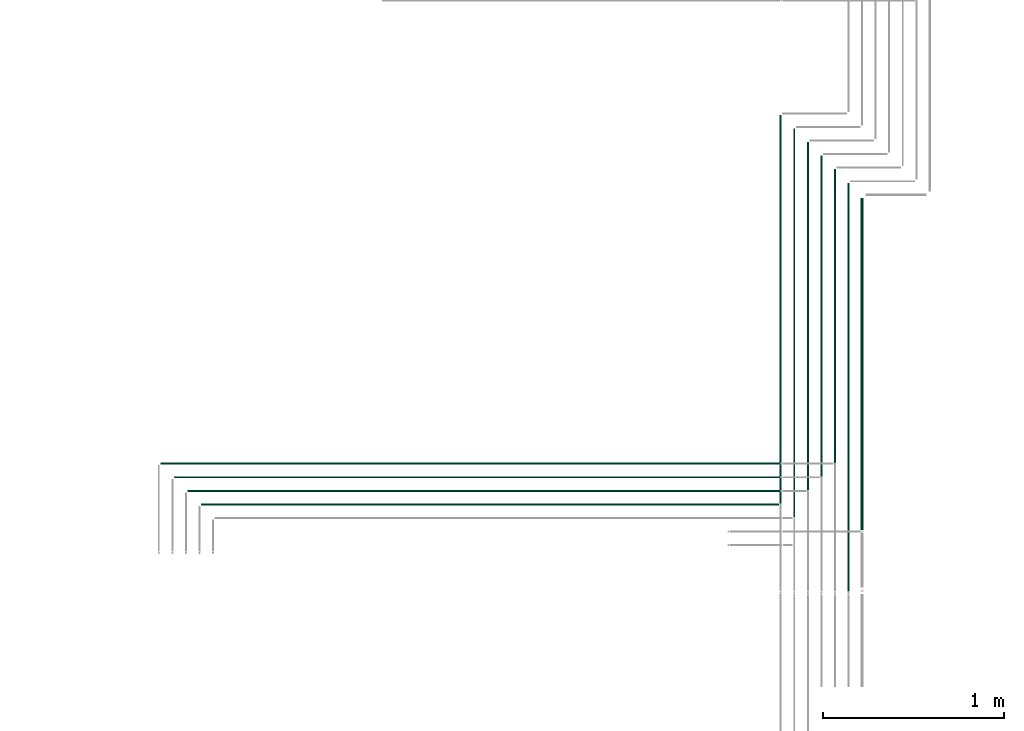
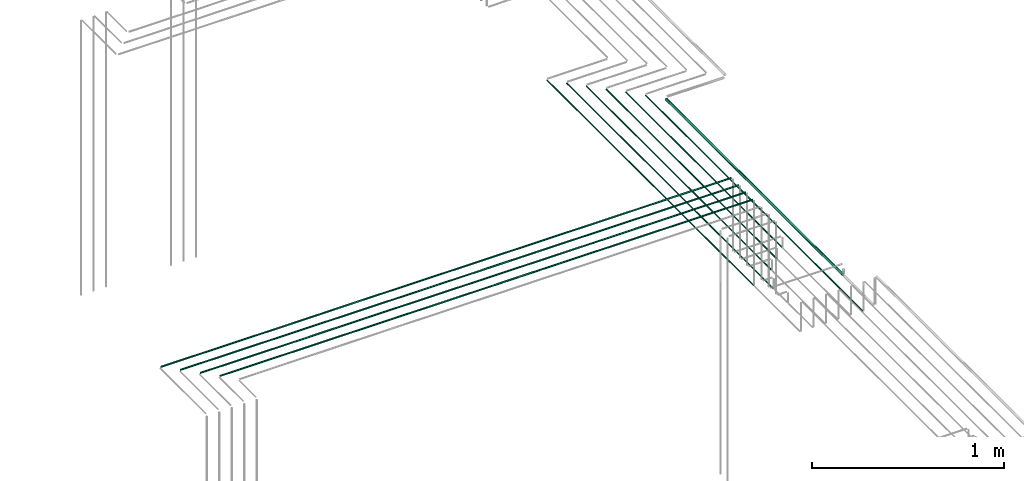
# One storey, part 20 of 89: 11 flow segments.
"""IFC2X3 building model written with IfcOpenShell, lengths in millimetres."""

from ifc_helpers import new_model, entity, si_unit, converted_unit, derived_unit, direction, frame, frame_2d, origin, origin_2d_with_axis, place, context, subcontext, project, spatial, circle, extrude, type_object, element, save


model = new_model("IFC2X3")

# Units and contexts
model_context = context("Model", 3, precision=0.01, world=origin(), true_north=direction((6.12303176911189e-17, 1.0)))
body_context = subcontext(model_context, "Body", "Model", "MODEL_VIEW")
ifc_project = project(units=[si_unit("LENGTHUNIT", "METRE", prefix="MILLI"), si_unit("AREAUNIT", "SQUARE_METRE"), si_unit("VOLUMEUNIT", "CUBIC_METRE"), converted_unit("PLANEANGLEUNIT", "DEGREE", entity("IfcRatioMeasure", 0.0174532925199433), si_unit("PLANEANGLEUNIT", "RADIAN"), dimensions=[0, 0, 0, 0, 0, 0, 0]), si_unit("MASSUNIT", "GRAM", prefix="KILO"), derived_unit("MASSDENSITYUNIT", [(si_unit("MASSUNIT", "GRAM", prefix="KILO"), 1), (si_unit("LENGTHUNIT", "METRE"), -3)]), derived_unit("MOMENTOFINERTIAUNIT", [(si_unit("LENGTHUNIT", "METRE"), 4)]), si_unit("TIMEUNIT", "SECOND"), si_unit("FREQUENCYUNIT", "HERTZ"), si_unit("THERMODYNAMICTEMPERATUREUNIT", "DEGREE_CELSIUS"), derived_unit("THERMALTRANSMITTANCEUNIT", [(si_unit("MASSUNIT", "GRAM", prefix="KILO"), 1), (si_unit("THERMODYNAMICTEMPERATUREUNIT", "KELVIN"), -1), (si_unit("TIMEUNIT", "SECOND"), -3)]), derived_unit("VOLUMETRICFLOWRATEUNIT", [(si_unit("LENGTHUNIT", "METRE"), 3), (si_unit("TIMEUNIT", "SECOND"), -1)]), derived_unit("MASSFLOWRATEUNIT", [(si_unit("MASSUNIT", "GRAM", prefix="KILO"), 1), (si_unit("TIMEUNIT", "SECOND"), -1)]), derived_unit("ROTATIONALFREQUENCYUNIT", [(si_unit("TIMEUNIT", "SECOND"), -1)]), si_unit("ELECTRICCURRENTUNIT", "AMPERE"), si_unit("ELECTRICVOLTAGEUNIT", "VOLT"), si_unit("POWERUNIT", "WATT"), si_unit("FORCEUNIT", "NEWTON", prefix="KILO"), si_unit("ILLUMINANCEUNIT", "LUX"), si_unit("LUMINOUSFLUXUNIT", "LUMEN"), si_unit("LUMINOUSINTENSITYUNIT", "CANDELA"), derived_unit("USERDEFINED", [(si_unit("MASSUNIT", "GRAM", prefix="KILO"), -1), (si_unit("LENGTHUNIT", "METRE"), -2), (si_unit("TIMEUNIT", "SECOND"), 3), (si_unit("LUMINOUSFLUXUNIT", "LUMEN"), 1)]), derived_unit("LINEARVELOCITYUNIT", [(si_unit("LENGTHUNIT", "METRE"), 1), (si_unit("TIMEUNIT", "SECOND"), -1)]), si_unit("PRESSUREUNIT", "PASCAL"), derived_unit("USERDEFINED", [(si_unit("LENGTHUNIT", "METRE"), -2), (si_unit("MASSUNIT", "GRAM", prefix="KILO"), 1), (si_unit("TIMEUNIT", "SECOND"), -2)]), derived_unit("LINEARFORCEUNIT", [(si_unit("MASSUNIT", "GRAM", prefix="KILO"), 1), (si_unit("LENGTHUNIT", "METRE"), 1), (si_unit("TIMEUNIT", "SECOND"), -2), (si_unit("LENGTHUNIT", "METRE"), -1)]), derived_unit("PLANARFORCEUNIT", [(si_unit("MASSUNIT", "GRAM", prefix="KILO"), 1), (si_unit("LENGTHUNIT", "METRE"), 1), (si_unit("TIMEUNIT", "SECOND"), -2), (si_unit("LENGTHUNIT", "METRE"), -2)])], contexts=[model_context])

# Site, building, storey
site_placement = place(None, frame((0.0, -0.00077364408347762, 0.0)))
site = spatial("IfcSite", under=ifc_project, at=site_placement, CompositionType="ELEMENT")
building_placement = place(site_placement, origin())
building = spatial("IfcBuilding", under=site, at=building_placement, CompositionType="ELEMENT")
storey_placement = place(building_placement, frame((0.0, 0.0, 24000.0)))
storey = spatial("IfcBuildingStorey", under=building, at=storey_placement, CompositionType="ELEMENT", Elevation=24000.0)

# Flow segments
pipe_segment_type = type_object("IfcPipeSegmentType", PredefinedType="NOTDEFINED")
flow_segment_1_placement = place(storey_placement, frame((64016.1933873496, 5207.64530556804, 3144.40472776411)))
element("IfcFlowSegment", 1, at=flow_segment_1_placement, inside=storey, type_object=pipe_segment_type, context=body_context, shape_type="SweptSolid", body=[
    extrude(circle(Radius=4.0, at=origin_2d_with_axis()), frame((0.0, 5.59527223593232, 5.59527223591499), z_axis=(1.0, 0.0, 0.0), x_axis=(0.0, -1.0, 0.0)), (0.0, 0.0, 1.0), 3193.8068812052),
])
flow_segment_2_placement = place(storey_placement, frame((63941.1933873496, 5282.64530556806, 3144.40472776411)))
element("IfcFlowSegment", 2, at=flow_segment_2_placement, inside=storey, type_object=pipe_segment_type, context=body_context, shape_type="SweptSolid", body=[
    extrude(circle(Radius=4.0, at=origin_2d_with_axis()), frame((0.0, 5.5952722359269, 5.59527223591499), z_axis=(1.0, 0.0, 0.0), x_axis=(0.0, -1.0, 0.0)), (0.0, 0.0, 1.0), 3271.21994490211),
])
flow_segment_3_placement = place(storey_placement, frame((63866.1933873496, 5357.64530556807, 3144.40472776411)))
element("IfcFlowSegment", 3, at=flow_segment_3_placement, inside=storey, type_object=pipe_segment_type, context=body_context, shape_type="SweptSolid", body=[
    extrude(circle(Radius=4.0, at=origin_2d_with_axis()), frame((0.0, 5.59527223592799, 5.59527223591499), z_axis=(1.0, 0.0, 0.0), x_axis=(0.0, -1.0, 0.0)), (0.0, 0.0, 1.0), 3346.21994490211),
])
flow_segment_4_placement = place(storey_placement, frame((63791.1933873496, 5432.64530556807, 3144.40472776411)))
element("IfcFlowSegment", 4, at=flow_segment_4_placement, inside=storey, type_object=pipe_segment_type, context=body_context, shape_type="SweptSolid", body=[
    extrude(circle(Radius=4.0, at=origin_2d_with_axis()), frame((0.0, 5.5952722359269, 5.59527223591499), z_axis=(1.0, 0.0, 0.0), x_axis=(0.0, -1.0, 0.0)), (0.0, 0.0, 1.0), 3421.2199449021),
])
flow_segment_5_placement = place(storey_placement, frame((67214.4049963189, 5218.24057780396, 2594.40472776409)))
element("IfcFlowSegment", 5, at=flow_segment_5_placement, inside=storey, type_object=pipe_segment_type, context=body_context, shape_type="SweptSolid", body=[
    extrude(circle(Radius=4.0, at=origin_2d_with_axis()), frame((5.59527223591499, 0.0, 5.59527223591499), z_axis=(0.0, 1.0, 0.0), x_axis=(1.0, 0.0, 0.0)), (0.0, 0.0, 1.0), 2146.75942219579),
])
flow_segment_6_placement = place(storey_placement, frame((67289.4049963189, 5143.24057780394, 2594.40472776409)))
element("IfcFlowSegment", 6, at=flow_segment_6_placement, inside=storey, type_object=pipe_segment_type, context=body_context, shape_type="SweptSolid", body=[
    extrude(circle(Radius=4.0, at=origin_2d_with_axis()), frame((5.59527223591499, 0.0, 5.59527223591499), z_axis=(0.0, 1.0, 0.0), x_axis=(-1.0, 0.0, 0.0)), (0.0, 0.0, 1.0), 2146.75942219581),
])
flow_segment_7_placement = place(storey_placement, frame((67364.4049963189, 5293.24057780397, 2594.40472776409)))
element("IfcFlowSegment", 7, at=flow_segment_7_placement, inside=storey, type_object=pipe_segment_type, context=body_context, shape_type="SweptSolid", body=[
    extrude(circle(Radius=4.0, at=origin_2d_with_axis()), frame((5.59527223591499, 0.0, 5.59527223591499), z_axis=(0.0, 1.0, 0.0), x_axis=(-1.0, 0.0, 0.0)), (0.0, 0.0, 1.0), 1921.75942219579),
])
flow_segment_8_placement = place(storey_placement, frame((67439.4049963189, 5368.24057780398, 2594.40472776409)))
element("IfcFlowSegment", 8, at=flow_segment_8_placement, inside=storey, type_object=pipe_segment_type, context=body_context, shape_type="SweptSolid", body=[
    extrude(circle(Radius=4.0, at=origin_2d_with_axis()), frame((5.59527223591499, 0.0, 5.59527223591499), z_axis=(0.0, 1.0, 0.0), x_axis=(1.0, 0.0, 0.0)), (0.0, 0.0, 1.0), 1771.75942219578),
])
flow_segment_9_placement = place(storey_placement, frame((67514.4049963189, 5443.24057780399, 2594.40472776409)))
element("IfcFlowSegment", 9, at=flow_segment_9_placement, inside=storey, type_object=pipe_segment_type, context=body_context, shape_type="SweptSolid", body=[
    extrude(circle(Radius=4.0, at=origin_2d_with_axis()), frame((5.59527223591499, 0.0, 5.59527223591499), z_axis=(0.0, 1.0, 0.0), x_axis=(1.0, 0.0, 0.0)), (0.0, 0.0, 1.0), 1621.75942219577),
])
flow_segment_10_placement = place(storey_placement, frame((67660.9049963189, 5071.28819852052, 2590.90472776409)))
element("IfcFlowSegment", 10, at=flow_segment_10_placement, inside=storey, type_object=pipe_segment_type, context=body_context, shape_type="SweptSolid", body=[
    extrude(circle(Radius=7.5, at=origin_2d_with_axis()), frame((9.09527223591419, 0.0, 9.09527223591419), z_axis=(0.0, 1.0, 0.0), x_axis=(1.0, 0.0, 0.0)), (0.0, 0.0, 1.0), 1835.71180147923),
])
flow_segment_11_placement = place(storey_placement, frame((67589.4049963189, 4732.69579689046, 2594.40472776409)))
element("IfcFlowSegment", 11, at=flow_segment_11_placement, inside=storey, type_object=pipe_segment_type, context=body_context, shape_type="SweptSolid", body=[
    extrude(circle(Radius=4.0, at=frame_2d((8.66293703438714e-12, 0.0), x_axis=(1.0, 0.0))), frame((5.59527223591499, 0.0, 5.59527223591499), z_axis=(0.0, 1.0, 0.0), x_axis=(-1.0, 0.0, 0.0)), (0.0, 0.0, 1.0), 2257.3042031093),
])

save(model, "model.ifc")
